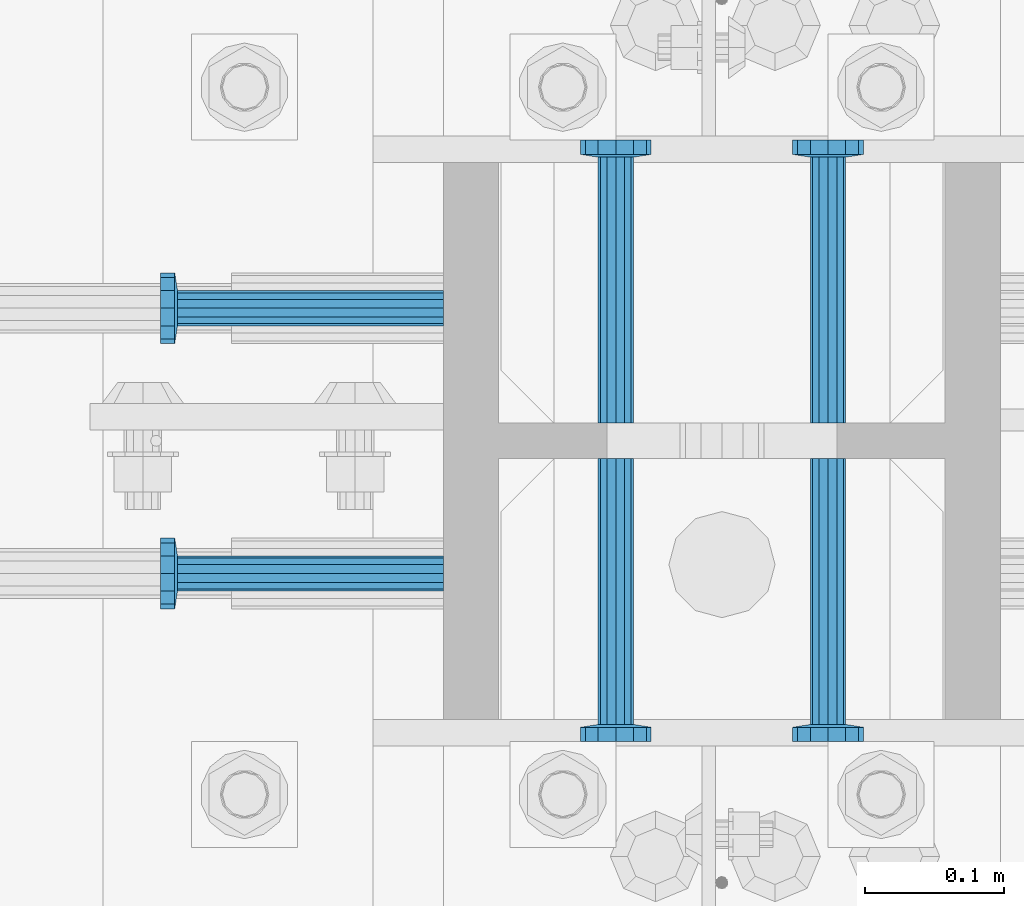
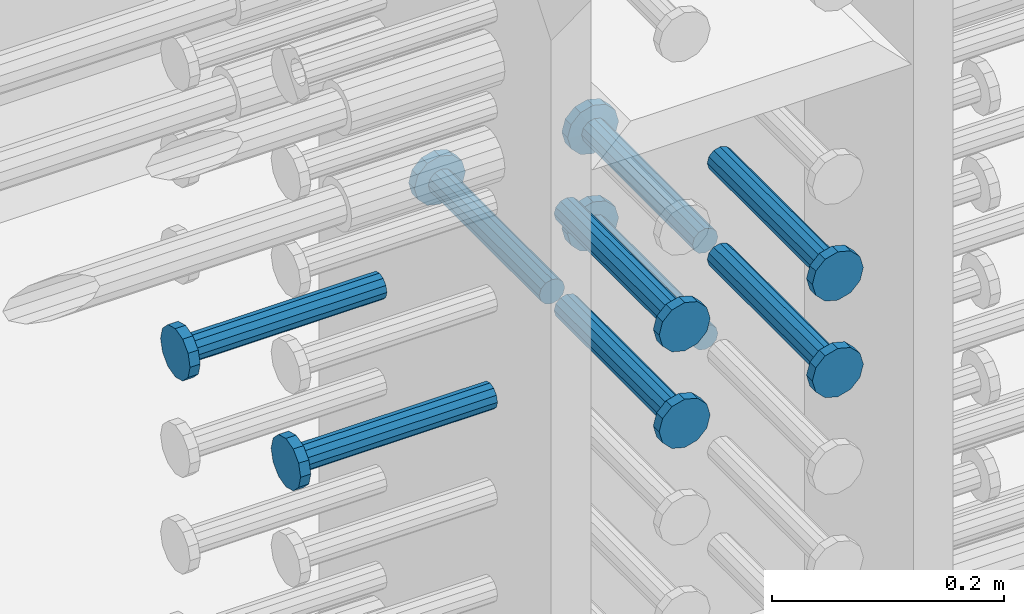
# One storey, part 1191 of 1763: 9 beams, 1 element without a shape of its own.
"""IFC2X3 building model written with IfcOpenShell, lengths in millimetres."""

import ifcopenshell
import ifcopenshell.guid

model = None  # the IFC model being written
_history = None  # IfcOwnerHistory: only IFC2X3 demands one
_inside = {}  # id of a spatial element -> (the spatial element, [elements in it])
_under = {}  # id of a project, library or spatial element -> (it, [spatial elements below it])
_declared = {}  # id of a project -> (the project, [libraries it declares])
_typed = {}  # id of a type object -> (the type object, [elements of that type])
_made_of = {}  # id of a material, layer set ... -> (it, [elements and type objects made of it])


def new_model(schema):
    """Start an empty IFC model of exactly this schema.

    Asked for "IFC4X3", IfcOpenShell would pick the latest addendum, in which some entities
    have other attributes; the version numbers below select the first issue.
    IFC2X3 requires an IfcOwnerHistory on every rooted entity: one is made here for all.
    """
    global model, _history
    if schema == "IFC4X3":
        model = ifcopenshell.file(schema_version=(4, 3, 0, 0))
    else:
        model = ifcopenshell.file(schema=schema)
    _inside.clear()
    _under.clear()
    _declared.clear()
    _typed.clear()
    _made_of.clear()
    _history = None
    if model.schema == "IFC2X3":
        org = make("IfcOrganization", Name="unknown")
        user = make(
            "IfcPersonAndOrganization",
            ThePerson=make("IfcPerson", FamilyName="unknown"),
            TheOrganization=org,
        )
        app = make(
            "IfcApplication",
            ApplicationDeveloper=org,
            Version="unknown",
            ApplicationFullName="unknown",
            ApplicationIdentifier="unknown",
        )
        _history = make(
            "IfcOwnerHistory",
            OwningUser=user,
            OwningApplication=app,
            ChangeAction="ADDED",
            CreationDate=0,
        )
    return model


def make(cls, **values):
    """One entity of the class cls with the attributes given. An attribute that is None is left unset."""
    return model.create_entity(
        cls, **{name: value for name, value in values.items() if value is not None}
    )


def rooted(cls, **values):
    """An entity with a GlobalId (a new one), such as an element, a storey or a relation."""
    return make(cls, GlobalId=ifcopenshell.guid.new(), OwnerHistory=_history, **values)


def si_unit(unit_type, name, prefix=None):
    """IfcSIUnit, for example si_unit("LENGTHUNIT", "METRE", prefix="MILLI")."""
    return make("IfcSIUnit", UnitType=unit_type, Prefix=prefix, Name=name)


def assignment(units):
    """IfcUnitAssignment: the units of a project."""
    return None if units is None else make("IfcUnitAssignment", Units=units)


def point(xyz):
    """IfcCartesianPoint."""
    return None if xyz is None else make("IfcCartesianPoint", Coordinates=xyz)


def direction(xyz):
    """IfcDirection."""
    return None if xyz is None else make("IfcDirection", DirectionRatios=xyz)


def frame(location, z_axis=None, x_axis=None):
    """IfcAxis2Placement3D, a coordinate frame: its origin and axes. An axis left out is left unset."""
    return make(
        "IfcAxis2Placement3D",
        Location=point(location),
        Axis=direction(z_axis),
        RefDirection=direction(x_axis),
    )


def origin_with_axes():
    """The frame at (0, 0, 0) with the z axis (0, 0, 1) and the x axis (1, 0, 0) written out."""
    return frame((0.0, 0.0, 0.0), z_axis=(0.0, 0.0, 1.0), x_axis=(1.0, 0.0, 0.0))


def place(relative_to, where):
    """IfcLocalPlacement: puts the frame where relative to a parent placement (None: the world)."""
    return make(
        "IfcLocalPlacement", PlacementRelTo=relative_to, RelativePlacement=where
    )


def context(
    kind, dimensions, precision=None, world=None, true_north=None, identifier=None
):
    """IfcGeometricRepresentationContext, for example the 3D "Model" context."""
    return make(
        "IfcGeometricRepresentationContext",
        ContextIdentifier=identifier,
        ContextType=kind,
        CoordinateSpaceDimension=dimensions,
        Precision=precision,
        WorldCoordinateSystem=world,
        TrueNorth=true_north,
    )


def subcontext(parent, identifier, kind, view, scale=None):
    """IfcGeometricRepresentationSubContext, for example "Body" below "Model"."""
    return make(
        "IfcGeometricRepresentationSubContext",
        ContextIdentifier=identifier,
        ContextType=kind,
        ParentContext=parent,
        TargetScale=scale,
        TargetView=view,
    )


def project(units=None, contexts=None):
    """IfcProject with its units and contexts."""
    return rooted(
        "IfcProject",
        Name="project",
        RepresentationContexts=contexts,
        UnitsInContext=assignment(units),
    )


def spatial(cls, under=None, at=None, **own):
    """A site, building, storey or space (cls), placed at a placement, below another one or the project."""
    s = rooted(cls, ObjectPlacement=at, **own)
    if under is not None:
        _under.setdefault(under.id(), (under, []))[1].append(s)
    return s


def faces_of(points, faces, orient=None, outer=None):
    """IfcFace entities. A face is a list of loops; a loop is a list of indices into points, from 0.

    orient and outer hold one flag for each loop. By default every Orientation is true, the
    first loop of a face is its IfcFaceOuterBound and the others are IfcFaceBound.
    """
    made = []
    for i, loops in enumerate(faces):
        bounds = []
        for j, loop in enumerate(loops):
            is_outer = j == 0 if outer is None else outer[i][j]
            bounds.append(
                make(
                    "IfcFaceOuterBound" if is_outer else "IfcFaceBound",
                    Bound=make("IfcPolyLoop", Polygon=[points[k] for k in loop]),
                    Orientation=True if orient is None else orient[i][j],
                )
            )
        made.append(make("IfcFace", Bounds=bounds))
    return made


def faceted_brep(points, faces, orient=None, outer=None, voids=None):
    """IfcFacetedBrep: a solid bounded by flat faces; with voids (closed shells), ...WithVoids."""
    shared = [point(p) for p in points]
    hull = make("IfcClosedShell", CfsFaces=faces_of(shared, faces, orient, outer))
    if voids is None:
        return make("IfcFacetedBrep", Outer=hull)
    return make(
        "IfcFacetedBrepWithVoids",
        Outer=hull,
        Voids=[
            make(cls, CfsFaces=faces_of(shared, fs, o, b)) for cls, fs, o, b in voids
        ],
    )


def shape(context_of_items, identifier, shape_type, items):
    """IfcShapeRepresentation: the items that make up one representation, for example the "Body"."""
    return make(
        "IfcShapeRepresentation",
        ContextOfItems=context_of_items,
        RepresentationIdentifier=identifier,
        RepresentationType=shape_type,
        Items=items,
    )


def material(Name=None, Category=None):
    """IfcMaterial."""
    return make("IfcMaterial", Name=Name, Category=Category)


def made_of(thing, what):
    """Note that an element or type object is made of a material, layer set ...; save() writes the relation."""
    if what is not None:
        _made_of.setdefault(what.id(), (what, []))[1].append(thing)
    return thing


def type_object(cls, material=None, **own):
    """A type object (cls), such as IfcWallType, which elements share."""
    return made_of(rooted(cls, **own), material)


def element(
    cls,
    number,
    at=None,
    inside=None,
    cuts=None,
    type_object=None,
    material=None,
    context=None,
    identifier="Body",
    shape_type=None,
    held_by="IfcProductDefinitionShape",
    body=None,
    shapes=None,
    **own,
):
    """One element of the class cls, such as IfcWall. Its Tag is "e" and its number.

    at: its placement. inside: the storey or other place that contains it. cuts: it is an
    opening in that element (IfcRelVoidsElement). A single representation is given by context,
    identifier, shape_type and body (its items); several are given by shapes. held_by: the class
    of the entity that holds the representations. save() writes the other relations.
    """
    e = rooted(cls, Tag="e%d" % number, ObjectPlacement=at, **own)
    if body is not None:
        shapes = [shape(context, identifier, shape_type, body)]
    if shapes is not None:
        e.Representation = make(held_by, Representations=shapes)
    if inside is not None:
        _inside.setdefault(inside.id(), (inside, []))[1].append(e)
    if cuts is not None:
        rooted(
            "IfcRelVoidsElement", RelatingBuildingElement=cuts, RelatedOpeningElement=e
        )
    if type_object is not None:
        _typed.setdefault(type_object.id(), (type_object, []))[1].append(e)
    return made_of(e, material)


def aggregate(whole, parts):
    """IfcRelAggregates: a whole, such as a stair, and the parts it consists of."""
    return rooted("IfcRelAggregates", RelatingObject=whole, RelatedObjects=parts)


def save(model, path):
    """Write the relations noted so far, then the file.

    IfcRelAggregates (storeys below a building ...), IfcRelContainedInSpatialStructure (elements
    in a storey), IfcRelDefinesByType, IfcRelAssociatesMaterial and IfcRelDeclares: one each for
    every whole, place, type object, material and project.
    """
    for whole, parts in _under.values():
        aggregate(whole, parts)
    for where, things in _inside.values():
        rooted(
            "IfcRelContainedInSpatialStructure",
            RelatedElements=things,
            RelatingStructure=where,
        )
    for kind, things in _typed.values():
        rooted("IfcRelDefinesByType", RelatedObjects=things, RelatingType=kind)
    for what, things in _made_of.values():
        rooted("IfcRelAssociatesMaterial", RelatedObjects=things, RelatingMaterial=what)
    for by, libraries in _declared.values():
        rooted("IfcRelDeclares", RelatingContext=by, RelatedDefinitions=libraries)
    model.write(path)


model = new_model("IFC2X3")

# Units and contexts
model_context = context("Model", 3, precision=1e-05, world=origin_with_axes())
body_context = subcontext(model_context, "Body", "Model", "MODEL_VIEW")
ifc_project = project(units=[si_unit("LENGTHUNIT", "METRE", prefix="MILLI"), si_unit("AREAUNIT", "SQUARE_METRE"), si_unit("VOLUMEUNIT", "CUBIC_METRE"), si_unit("MASSUNIT", "GRAM", prefix="KILO"), si_unit("TIMEUNIT", "SECOND"), si_unit("PLANEANGLEUNIT", "RADIAN"), si_unit("SOLIDANGLEUNIT", "STERADIAN"), si_unit("THERMODYNAMICTEMPERATUREUNIT", "DEGREE_CELSIUS"), si_unit("LUMINOUSINTENSITYUNIT", "LUMEN")], contexts=[model_context])

# Site, building, storey
site_placement = place(None, origin_with_axes())
site = spatial("IfcSite", under=ifc_project, at=site_placement, CompositionType="ELEMENT")
building_placement = place(site_placement, origin_with_axes())
building = spatial("IfcBuilding", under=site, at=building_placement, Name="Undefined", CompositionType="ELEMENT")
storey_placement = place(building_placement, origin_with_axes())
storey = spatial("IfcBuildingStorey", under=building, at=storey_placement, Name="Undefined", CompositionType="ELEMENT", Elevation=0.0)

# Assembly, beams
assembly_placement = place(storey_placement, origin_with_axes())
assembly = element("IfcElementAssembly", 1, at=assembly_placement, inside=storey, Name="COLUMN", AssemblyPlace="NOTDEFINED", PredefinedType="RIGID_FRAME")
ifc_material = material(Name="STEEL/A108")
beam_type = type_object("IfcBeamType", PredefinedType="NOTDEFINED")
beam_1_placement = place(assembly_placement, frame((-72567.2373420903, 444.499999886566, 4622.80000000005), z_axis=(1.0, 0.0, 0.0), x_axis=(0.0, -1.0, 0.0)))
beam_1 = element("IfcBeam", 2, at=beam_1_placement, type_object=beam_type, material=ifc_material, Name="HEADED STUD ANCHOR", context=body_context, shape_type="Brep", body=[
    faceted_brep([(0.0, -12.6999999999971, -1.81898940354586e-12), (3.63797880709171e-12, -11.0, -6.34999990463257), (191.00799999576, -11.0, -6.34999990454889), (191.007999995752, -12.6999998092651, 8.36735125631094e-11), (7.27595761418343e-12, -6.34999990463257, -11.0), (191.00799999576, -6.34999990463257, -10.9999999999163), (3.63797880709171e-12, 0.0, -12.6999998092651), (191.00799999576, 0.0, -12.6999998091815), (7.27595761418343e-12, 6.34999990463257, -11.0), (191.00799999576, 6.34999990463257, -10.9999999999163), (3.63797880709171e-12, 11.0, -6.34999990463257), (191.00799999576, 11.0, -6.34999990454889), (0.0, 12.6999999999971, -1.81898940354586e-12), (191.007999995752, 12.6999998092651, 8.36735125631094e-11), (0.0, 11.0, 6.34999990463257), (191.007999995752, 11.0, 6.34999990471624), (-3.63797880709171e-12, 6.34999990463257, 11.0), (191.007999995749, 6.34999990463257, 11.0000000000837), (-3.63797880709171e-12, 0.0, 12.6999998092651), (191.007999995749, 0.0, 12.6999998093488), (-3.63797880709171e-12, -6.34999990463257, 11.0), (191.007999995749, -6.34999990463257, 11.0000000000837), (0.0, -11.0, 6.34999990463257), (191.007999995752, -11.0, 6.34999990471624), (193.039999995715, -22.0, -12.6999998091796), (193.039999995708, -25.3999996185303, 8.54925019666553e-11), (193.039999995719, -12.6999998092651, -21.9999999999145), (193.039999995719, 0.0, -25.3999996184448), (193.039999995719, 12.6999998092651, -21.9999999999145), (193.039999995715, 22.0, -12.6999998091796), (193.039999995708, 25.3999996185303, 8.54925019666553e-11), (193.039999995704, 22.0, 12.6999998093506), (193.039999995701, 12.6999998092651, 22.0000000000855), (193.039999995697, 0.0, 25.3999996186158), (193.039999995701, -12.6999998092651, 22.0000000000855), (193.039999995704, -22.0, 12.6999998093506), (203.199999995486, -22.0, -12.6999998091742), (203.199999995482, -25.3999996185303, 9.09494701772928e-11), (203.199999995493, -12.6999998092651, -21.9999999999091), (203.199999995493, 0.0, -25.3999996184393), (203.199999995493, 12.6999998092651, -21.9999999999091), (203.199999995486, 22.0, -12.6999998091742), (203.199999995482, 25.3999996185303, 9.09494701772928e-11), (203.199999995479, 22.0, 12.6999998093561), (203.199999995475, 12.6999998092651, 22.0000000000909), (203.199999995471, 0.0, 25.3999996186212), (203.199999995475, -12.6999998092651, 22.0000000000909), (203.199999995479, -22.0, 12.6999998093561)], [[[0, 1, 2, 3]], [[1, 4, 5, 2]], [[4, 6, 7, 5]], [[6, 8, 9, 7]], [[8, 10, 11, 9]], [[10, 12, 13, 11]], [[12, 14, 15, 13]], [[14, 16, 17, 15]], [[16, 18, 19, 17]], [[18, 20, 21, 19]], [[20, 22, 23, 21]], [[22, 0, 3, 23]], [[22, 20, 18, 16, 14, 12, 10, 8, 6, 4, 1, 0]], [[3, 2, 24, 25]], [[2, 5, 26, 24]], [[5, 7, 27, 26]], [[7, 9, 28, 27]], [[9, 11, 29, 28]], [[11, 13, 30, 29]], [[13, 15, 31, 30]], [[15, 17, 32, 31]], [[17, 19, 33, 32]], [[19, 21, 34, 33]], [[21, 23, 35, 34]], [[23, 3, 25, 35]], [[25, 24, 36, 37]], [[24, 26, 38, 36]], [[26, 27, 39, 38]], [[27, 28, 40, 39]], [[28, 29, 41, 40]], [[29, 30, 42, 41]], [[30, 31, 43, 42]], [[31, 32, 44, 43]], [[32, 33, 45, 44]], [[33, 34, 46, 45]], [[34, 35, 47, 46]], [[35, 25, 37, 47]], [[38, 39, 40, 41, 42, 43, 44, 45, 46, 47, 37, 36]]]),
])
beam_2_placement = place(assembly_placement, frame((-72414.8373420912, 444.500000000843, 4622.80000000005), z_axis=(1.0, 0.0, 0.0), x_axis=(0.0, -1.0, 0.0)))
beam_2 = element("IfcBeam", 3, at=beam_2_placement, type_object=beam_type, material=ifc_material, Name="HEADED STUD ANCHOR", context=body_context, shape_type="Brep", body=[
    faceted_brep([(0.0, -12.6999999999971, -1.81898940354586e-12), (3.63797880709171e-12, -11.0, -6.34999990463257), (191.00799999576, -11.0, -6.34999990454889), (191.007999995752, -12.6999998092651, 8.36735125631094e-11), (7.27595761418343e-12, -6.34999990463257, -11.0), (191.00799999576, -6.34999990463257, -10.9999999999163), (3.63797880709171e-12, 0.0, -12.6999998092651), (191.00799999576, 0.0, -12.6999998091815), (7.27595761418343e-12, 6.34999990463257, -11.0), (191.00799999576, 6.34999990463257, -10.9999999999163), (3.63797880709171e-12, 11.0, -6.34999990463257), (191.00799999576, 11.0, -6.34999990454889), (0.0, 12.6999999999971, -1.81898940354586e-12), (191.007999995752, 12.6999998092651, 8.36735125631094e-11), (0.0, 11.0, 6.34999990463257), (191.007999995752, 11.0, 6.34999990471624), (-3.63797880709171e-12, 6.34999990463257, 11.0), (191.007999995749, 6.34999990463257, 11.0000000000837), (-3.63797880709171e-12, 0.0, 12.6999998092651), (191.007999995749, 0.0, 12.6999998093488), (-3.63797880709171e-12, -6.34999990463257, 11.0), (191.007999995749, -6.34999990463257, 11.0000000000837), (0.0, -11.0, 6.34999990463257), (191.007999995752, -11.0, 6.34999990471624), (193.039999995715, -22.0, -12.6999998091796), (193.039999995708, -25.3999996185303, 8.54925019666553e-11), (193.039999995719, -12.6999998092651, -21.9999999999145), (193.039999995719, 0.0, -25.3999996184448), (193.039999995719, 12.6999998092651, -21.9999999999145), (193.039999995715, 22.0, -12.6999998091796), (193.039999995708, 25.3999996185303, 8.54925019666553e-11), (193.039999995704, 22.0, 12.6999998093506), (193.039999995701, 12.6999998092651, 22.0000000000855), (193.039999995697, 0.0, 25.3999996186158), (193.039999995701, -12.6999998092651, 22.0000000000855), (193.039999995704, -22.0, 12.6999998093506), (203.199999995486, -22.0, -12.6999998091742), (203.199999995482, -25.3999996185303, 9.09494701772928e-11), (203.199999995493, -12.6999998092651, -21.9999999999091), (203.199999995493, 0.0, -25.3999996184393), (203.199999995493, 12.6999998092651, -21.9999999999091), (203.199999995486, 22.0, -12.6999998091742), (203.199999995482, 25.3999996185303, 9.09494701772928e-11), (203.199999995479, 22.0, 12.6999998093561), (203.199999995475, 12.6999998092651, 22.0000000000909), (203.199999995471, 0.0, 25.3999996186212), (203.199999995475, -12.6999998092651, 22.0000000000909), (203.199999995479, -22.0, 12.6999998093561)], [[[0, 1, 2, 3]], [[1, 4, 5, 2]], [[4, 6, 7, 5]], [[6, 8, 9, 7]], [[8, 10, 11, 9]], [[10, 12, 13, 11]], [[12, 14, 15, 13]], [[14, 16, 17, 15]], [[16, 18, 19, 17]], [[18, 20, 21, 19]], [[20, 22, 23, 21]], [[22, 0, 3, 23]], [[22, 20, 18, 16, 14, 12, 10, 8, 6, 4, 1, 0]], [[3, 2, 24, 25]], [[2, 5, 26, 24]], [[5, 7, 27, 26]], [[7, 9, 28, 27]], [[9, 11, 29, 28]], [[11, 13, 30, 29]], [[13, 15, 31, 30]], [[15, 17, 32, 31]], [[17, 19, 33, 32]], [[19, 21, 34, 33]], [[21, 23, 35, 34]], [[23, 3, 25, 35]], [[25, 24, 36, 37]], [[24, 26, 38, 36]], [[26, 27, 39, 38]], [[27, 28, 40, 39]], [[28, 29, 41, 40]], [[29, 30, 42, 41]], [[30, 31, 43, 42]], [[31, 32, 44, 43]], [[32, 33, 45, 44]], [[33, 34, 46, 45]], [[34, 35, 47, 46]], [[35, 25, 37, 47]], [[38, 39, 40, 41, 42, 43, 44, 45, 46, 47, 37, 36]]]),
])
beam_3_placement = place(assembly_placement, frame((-72414.837343099, 469.900000000843, 4521.20000000005), z_axis=(1.0, 0.0, 0.0), x_axis=(0.0, 1.0, 0.0)))
beam_3 = element("IfcBeam", 4, at=beam_3_placement, type_object=beam_type, material=ifc_material, Name="HEADED STUD ANCHOR", context=body_context, shape_type="Brep", body=[
    faceted_brep([(0.0, -12.6999999999971, -1.81898940354586e-12), (3.63797880709171e-12, -11.0, -6.34999990463257), (191.00799999576, -11.0, -6.34999990454889), (191.007999995752, -12.6999998092651, 8.36735125631094e-11), (7.27595761418343e-12, -6.34999990463257, -11.0), (191.00799999576, -6.34999990463257, -10.9999999999163), (3.63797880709171e-12, 0.0, -12.6999998092651), (191.00799999576, 0.0, -12.6999998091815), (7.27595761418343e-12, 6.34999990463257, -11.0), (191.00799999576, 6.34999990463257, -10.9999999999163), (3.63797880709171e-12, 11.0, -6.34999990463257), (191.00799999576, 11.0, -6.34999990454889), (0.0, 12.6999999999971, -1.81898940354586e-12), (191.007999995752, 12.6999998092651, 8.36735125631094e-11), (0.0, 11.0, 6.34999990463257), (191.007999995752, 11.0, 6.34999990471624), (-3.63797880709171e-12, 6.34999990463257, 11.0), (191.007999995749, 6.34999990463257, 11.0000000000837), (-3.63797880709171e-12, 0.0, 12.6999998092651), (191.007999995749, 0.0, 12.6999998093488), (-3.63797880709171e-12, -6.34999990463257, 11.0), (191.007999995749, -6.34999990463257, 11.0000000000837), (0.0, -11.0, 6.34999990463257), (191.007999995752, -11.0, 6.34999990471624), (193.039999995715, -22.0, -12.6999998091796), (193.039999995708, -25.3999996185303, 8.54925019666553e-11), (193.039999995719, -12.6999998092651, -21.9999999999145), (193.039999995719, 0.0, -25.3999996184448), (193.039999995719, 12.6999998092651, -21.9999999999145), (193.039999995715, 22.0, -12.6999998091796), (193.039999995708, 25.3999996185303, 8.54925019666553e-11), (193.039999995704, 22.0, 12.6999998093506), (193.039999995701, 12.6999998092651, 22.0000000000855), (193.039999995697, 0.0, 25.3999996186158), (193.039999995701, -12.6999998092651, 22.0000000000855), (193.039999995704, -22.0, 12.6999998093506), (203.199999995486, -22.0, -12.6999998091742), (203.199999995482, -25.3999996185303, 9.09494701772928e-11), (203.199999995493, -12.6999998092651, -21.9999999999091), (203.199999995493, 0.0, -25.3999996184393), (203.199999995493, 12.6999998092651, -21.9999999999091), (203.199999995486, 22.0, -12.6999998091742), (203.199999995482, 25.3999996185303, 9.09494701772928e-11), (203.199999995479, 22.0, 12.6999998093561), (203.199999995475, 12.6999998092651, 22.0000000000909), (203.199999995471, 0.0, 25.3999996186212), (203.199999995475, -12.6999998092651, 22.0000000000909), (203.199999995479, -22.0, 12.6999998093561)], [[[0, 1, 2, 3]], [[1, 4, 5, 2]], [[4, 6, 7, 5]], [[6, 8, 9, 7]], [[8, 10, 11, 9]], [[10, 12, 13, 11]], [[12, 14, 15, 13]], [[14, 16, 17, 15]], [[16, 18, 19, 17]], [[18, 20, 21, 19]], [[20, 22, 23, 21]], [[22, 0, 3, 23]], [[22, 20, 18, 16, 14, 12, 10, 8, 6, 4, 1, 0]], [[3, 2, 24, 25]], [[2, 5, 26, 24]], [[5, 7, 27, 26]], [[7, 9, 28, 27]], [[9, 11, 29, 28]], [[11, 13, 30, 29]], [[13, 15, 31, 30]], [[15, 17, 32, 31]], [[17, 19, 33, 32]], [[19, 21, 34, 33]], [[21, 23, 35, 34]], [[23, 3, 25, 35]], [[25, 24, 36, 37]], [[24, 26, 38, 36]], [[26, 27, 39, 38]], [[27, 28, 40, 39]], [[28, 29, 41, 40]], [[29, 30, 42, 41]], [[30, 31, 43, 42]], [[31, 32, 44, 43]], [[32, 33, 45, 44]], [[33, 34, 46, 45]], [[34, 35, 47, 46]], [[35, 25, 37, 47]], [[38, 39, 40, 41, 42, 43, 44, 45, 46, 47, 37, 36]]]),
])
beam_4_placement = place(assembly_placement, frame((-72567.2373430988, 469.899999003702, 4521.20000000005), z_axis=(1.0, 0.0, 0.0), x_axis=(0.0, 1.0, 0.0)))
beam_4 = element("IfcBeam", 5, at=beam_4_placement, type_object=beam_type, material=ifc_material, Name="HEADED STUD ANCHOR", context=body_context, shape_type="Brep", body=[
    faceted_brep([(0.0, -12.6999999999971, -1.81898940354586e-12), (3.63797880709171e-12, -11.0, -6.34999990463257), (191.00799999576, -11.0, -6.34999990454889), (191.007999995752, -12.6999998092651, 8.36735125631094e-11), (7.27595761418343e-12, -6.34999990463257, -11.0), (191.00799999576, -6.34999990463257, -10.9999999999163), (3.63797880709171e-12, 0.0, -12.6999998092651), (191.00799999576, 0.0, -12.6999998091815), (7.27595761418343e-12, 6.34999990463257, -11.0), (191.00799999576, 6.34999990463257, -10.9999999999163), (3.63797880709171e-12, 11.0, -6.34999990463257), (191.00799999576, 11.0, -6.34999990454889), (0.0, 12.6999999999971, -1.81898940354586e-12), (191.007999995752, 12.6999998092651, 8.36735125631094e-11), (0.0, 11.0, 6.34999990463257), (191.007999995752, 11.0, 6.34999990471624), (-3.63797880709171e-12, 6.34999990463257, 11.0), (191.007999995749, 6.34999990463257, 11.0000000000837), (-3.63797880709171e-12, 0.0, 12.6999998092651), (191.007999995749, 0.0, 12.6999998093488), (-3.63797880709171e-12, -6.34999990463257, 11.0), (191.007999995749, -6.34999990463257, 11.0000000000837), (0.0, -11.0, 6.34999990463257), (191.007999995752, -11.0, 6.34999990471624), (193.039999995715, -22.0, -12.6999998091796), (193.039999995708, -25.3999996185303, 8.54925019666553e-11), (193.039999995719, -12.6999998092651, -21.9999999999145), (193.039999995719, 0.0, -25.3999996184448), (193.039999995719, 12.6999998092651, -21.9999999999145), (193.039999995715, 22.0, -12.6999998091796), (193.039999995708, 25.3999996185303, 8.54925019666553e-11), (193.039999995704, 22.0, 12.6999998093506), (193.039999995701, 12.6999998092651, 22.0000000000855), (193.039999995697, 0.0, 25.3999996186158), (193.039999995701, -12.6999998092651, 22.0000000000855), (193.039999995704, -22.0, 12.6999998093506), (203.199999995486, -22.0, -12.6999998091742), (203.199999995482, -25.3999996185303, 9.09494701772928e-11), (203.199999995493, -12.6999998092651, -21.9999999999091), (203.199999995493, 0.0, -25.3999996184393), (203.199999995493, 12.6999998092651, -21.9999999999091), (203.199999995486, 22.0, -12.6999998091742), (203.199999995482, 25.3999996185303, 9.09494701772928e-11), (203.199999995479, 22.0, 12.6999998093561), (203.199999995475, 12.6999998092651, 22.0000000000909), (203.199999995471, 0.0, 25.3999996186212), (203.199999995475, -12.6999998092651, 22.0000000000909), (203.199999995479, -22.0, 12.6999998093561)], [[[0, 1, 2, 3]], [[1, 4, 5, 2]], [[4, 6, 7, 5]], [[6, 8, 9, 7]], [[8, 10, 11, 9]], [[10, 12, 13, 11]], [[12, 14, 15, 13]], [[14, 16, 17, 15]], [[16, 18, 19, 17]], [[18, 20, 21, 19]], [[20, 22, 23, 21]], [[22, 0, 3, 23]], [[22, 20, 18, 16, 14, 12, 10, 8, 6, 4, 1, 0]], [[3, 2, 24, 25]], [[2, 5, 26, 24]], [[5, 7, 27, 26]], [[7, 9, 28, 27]], [[9, 11, 29, 28]], [[11, 13, 30, 29]], [[13, 15, 31, 30]], [[15, 17, 32, 31]], [[17, 19, 33, 32]], [[19, 21, 34, 33]], [[21, 23, 35, 34]], [[23, 3, 25, 35]], [[25, 24, 36, 37]], [[24, 26, 38, 36]], [[26, 27, 39, 38]], [[27, 28, 40, 39]], [[28, 29, 41, 40]], [[29, 30, 42, 41]], [[30, 31, 43, 42]], [[31, 32, 44, 43]], [[32, 33, 45, 44]], [[33, 34, 46, 45]], [[34, 35, 47, 46]], [[35, 25, 37, 47]], [[38, 39, 40, 41, 42, 43, 44, 45, 46, 47, 37, 36]]]),
])
beam_5_placement = place(assembly_placement, frame((-72691.0622049617, 552.45000000066, 4521.20000000005), z_axis=(0.0, 1.0, 0.0), x_axis=(-1.0, 0.0, 0.0)))
beam_5 = element("IfcBeam", 6, at=beam_5_placement, type_object=beam_type, material=ifc_material, Name="HEADED STUD ANCHOR", context=body_context, shape_type="Brep", body=[
    faceted_brep([(0.0, -12.6999999999971, -1.81898940354586e-12), (3.63797880709171e-12, -11.0, -6.34999990463257), (191.00799999576, -11.0, -6.34999990454889), (191.007999995752, -12.6999998092651, 8.36735125631094e-11), (7.27595761418343e-12, -6.34999990463257, -11.0), (191.00799999576, -6.34999990463257, -10.9999999999163), (3.63797880709171e-12, 0.0, -12.6999998092651), (191.00799999576, 0.0, -12.6999998091815), (7.27595761418343e-12, 6.34999990463257, -11.0), (191.00799999576, 6.34999990463257, -10.9999999999163), (3.63797880709171e-12, 11.0, -6.34999990463257), (191.00799999576, 11.0, -6.34999990454889), (0.0, 12.6999999999971, -1.81898940354586e-12), (191.007999995752, 12.6999998092651, 8.36735125631094e-11), (0.0, 11.0, 6.34999990463257), (191.007999995752, 11.0, 6.34999990471624), (-3.63797880709171e-12, 6.34999990463257, 11.0), (191.007999995749, 6.34999990463257, 11.0000000000837), (-3.63797880709171e-12, 0.0, 12.6999998092651), (191.007999995749, 0.0, 12.6999998093488), (-3.63797880709171e-12, -6.34999990463257, 11.0), (191.007999995749, -6.34999990463257, 11.0000000000837), (0.0, -11.0, 6.34999990463257), (191.007999995752, -11.0, 6.34999990471624), (193.039999995715, -22.0, -12.6999998091796), (193.039999995708, -25.3999996185303, 8.54925019666553e-11), (193.039999995719, -12.6999998092651, -21.9999999999145), (193.039999995719, 0.0, -25.3999996184448), (193.039999995719, 12.6999998092651, -21.9999999999145), (193.039999995715, 22.0, -12.6999998091796), (193.039999995708, 25.3999996185303, 8.54925019666553e-11), (193.039999995704, 22.0, 12.6999998093506), (193.039999995701, 12.6999998092651, 22.0000000000855), (193.039999995697, 0.0, 25.3999996186158), (193.039999995701, -12.6999998092651, 22.0000000000855), (193.039999995704, -22.0, 12.6999998093506), (203.199999995486, -22.0, -12.6999998091742), (203.199999995482, -25.3999996185303, 9.09494701772928e-11), (203.199999995493, -12.6999998092651, -21.9999999999091), (203.199999995493, 0.0, -25.3999996184393), (203.199999995493, 12.6999998092651, -21.9999999999091), (203.199999995486, 22.0, -12.6999998091742), (203.199999995482, 25.3999996185303, 9.09494701772928e-11), (203.199999995479, 22.0, 12.6999998093561), (203.199999995475, 12.6999998092651, 22.0000000000909), (203.199999995471, 0.0, 25.3999996186212), (203.199999995475, -12.6999998092651, 22.0000000000909), (203.199999995479, -22.0, 12.6999998093561)], [[[0, 1, 2, 3]], [[1, 4, 5, 2]], [[4, 6, 7, 5]], [[6, 8, 9, 7]], [[8, 10, 11, 9]], [[10, 12, 13, 11]], [[12, 14, 15, 13]], [[14, 16, 17, 15]], [[16, 18, 19, 17]], [[18, 20, 21, 19]], [[20, 22, 23, 21]], [[22, 0, 3, 23]], [[22, 20, 18, 16, 14, 12, 10, 8, 6, 4, 1, 0]], [[3, 2, 24, 25]], [[2, 5, 26, 24]], [[5, 7, 27, 26]], [[7, 9, 28, 27]], [[9, 11, 29, 28]], [[11, 13, 30, 29]], [[13, 15, 31, 30]], [[15, 17, 32, 31]], [[17, 19, 33, 32]], [[19, 21, 34, 33]], [[21, 23, 35, 34]], [[23, 3, 25, 35]], [[25, 24, 36, 37]], [[24, 26, 38, 36]], [[26, 27, 39, 38]], [[27, 28, 40, 39]], [[28, 29, 41, 40]], [[29, 30, 42, 41]], [[30, 31, 43, 42]], [[31, 32, 44, 43]], [[32, 33, 45, 44]], [[33, 34, 46, 45]], [[34, 35, 47, 46]], [[35, 25, 37, 47]], [[38, 39, 40, 41, 42, 43, 44, 45, 46, 47, 37, 36]]]),
])
beam_6_placement = place(assembly_placement, frame((-72691.0622736973, 361.950000000834, 4521.20000000005), z_axis=(0.0, 1.0, 0.0), x_axis=(-1.0, 0.0, 0.0)))
beam_6 = element("IfcBeam", 7, at=beam_6_placement, type_object=beam_type, material=ifc_material, Name="HEADED STUD ANCHOR", context=body_context, shape_type="Brep", body=[
    faceted_brep([(0.0, -12.6999999999971, -1.81898940354586e-12), (3.63797880709171e-12, -11.0, -6.34999990463257), (191.00799999576, -11.0, -6.34999990454889), (191.007999995752, -12.6999998092651, 8.36735125631094e-11), (7.27595761418343e-12, -6.34999990463257, -11.0), (191.00799999576, -6.34999990463257, -10.9999999999163), (3.63797880709171e-12, 0.0, -12.6999998092651), (191.00799999576, 0.0, -12.6999998091815), (7.27595761418343e-12, 6.34999990463257, -11.0), (191.00799999576, 6.34999990463257, -10.9999999999163), (3.63797880709171e-12, 11.0, -6.34999990463257), (191.00799999576, 11.0, -6.34999990454889), (0.0, 12.6999999999971, -1.81898940354586e-12), (191.007999995752, 12.6999998092651, 8.36735125631094e-11), (0.0, 11.0, 6.34999990463257), (191.007999995752, 11.0, 6.34999990471624), (-3.63797880709171e-12, 6.34999990463257, 11.0), (191.007999995749, 6.34999990463257, 11.0000000000837), (-3.63797880709171e-12, 0.0, 12.6999998092651), (191.007999995749, 0.0, 12.6999998093488), (-3.63797880709171e-12, -6.34999990463257, 11.0), (191.007999995749, -6.34999990463257, 11.0000000000837), (0.0, -11.0, 6.34999990463257), (191.007999995752, -11.0, 6.34999990471624), (193.039999995715, -22.0, -12.6999998091796), (193.039999995708, -25.3999996185303, 8.54925019666553e-11), (193.039999995719, -12.6999998092651, -21.9999999999145), (193.039999995719, 0.0, -25.3999996184448), (193.039999995719, 12.6999998092651, -21.9999999999145), (193.039999995715, 22.0, -12.6999998091796), (193.039999995708, 25.3999996185303, 8.54925019666553e-11), (193.039999995704, 22.0, 12.6999998093506), (193.039999995701, 12.6999998092651, 22.0000000000855), (193.039999995697, 0.0, 25.3999996186158), (193.039999995701, -12.6999998092651, 22.0000000000855), (193.039999995704, -22.0, 12.6999998093506), (203.199999995486, -22.0, -12.6999998091742), (203.199999995482, -25.3999996185303, 9.09494701772928e-11), (203.199999995493, -12.6999998092651, -21.9999999999091), (203.199999995493, 0.0, -25.3999996184393), (203.199999995493, 12.6999998092651, -21.9999999999091), (203.199999995486, 22.0, -12.6999998091742), (203.199999995482, 25.3999996185303, 9.09494701772928e-11), (203.199999995479, 22.0, 12.6999998093561), (203.199999995475, 12.6999998092651, 22.0000000000909), (203.199999995471, 0.0, 25.3999996186212), (203.199999995475, -12.6999998092651, 22.0000000000909), (203.199999995479, -22.0, 12.6999998093561)], [[[0, 1, 2, 3]], [[1, 4, 5, 2]], [[4, 6, 7, 5]], [[6, 8, 9, 7]], [[8, 10, 11, 9]], [[10, 12, 13, 11]], [[12, 14, 15, 13]], [[14, 16, 17, 15]], [[16, 18, 19, 17]], [[18, 20, 21, 19]], [[20, 22, 23, 21]], [[22, 0, 3, 23]], [[22, 20, 18, 16, 14, 12, 10, 8, 6, 4, 1, 0]], [[3, 2, 24, 25]], [[2, 5, 26, 24]], [[5, 7, 27, 26]], [[7, 9, 28, 27]], [[9, 11, 29, 28]], [[11, 13, 30, 29]], [[13, 15, 31, 30]], [[15, 17, 32, 31]], [[17, 19, 33, 32]], [[19, 21, 34, 33]], [[21, 23, 35, 34]], [[23, 3, 25, 35]], [[25, 24, 36, 37]], [[24, 26, 38, 36]], [[26, 27, 39, 38]], [[27, 28, 40, 39]], [[28, 29, 41, 40]], [[29, 30, 42, 41]], [[30, 31, 43, 42]], [[31, 32, 44, 43]], [[32, 33, 45, 44]], [[33, 34, 46, 45]], [[34, 35, 47, 46]], [[35, 25, 37, 47]], [[38, 39, 40, 41, 42, 43, 44, 45, 46, 47, 37, 36]]]),
])
beam_7_placement = place(assembly_placement, frame((-72567.2373420903, 444.499999886566, 4521.20000000005), z_axis=(1.0, 0.0, 0.0), x_axis=(0.0, -1.0, 0.0)))
beam_7 = element("IfcBeam", 8, at=beam_7_placement, type_object=beam_type, material=ifc_material, Name="HEADED STUD ANCHOR", context=body_context, shape_type="Brep", body=[
    faceted_brep([(0.0, -12.6999999999971, -1.81898940354586e-12), (3.63797880709171e-12, -11.0, -6.34999990463257), (191.00799999576, -11.0, -6.34999990454889), (191.007999995752, -12.6999998092651, 8.36735125631094e-11), (7.27595761418343e-12, -6.34999990463257, -11.0), (191.00799999576, -6.34999990463257, -10.9999999999163), (3.63797880709171e-12, 0.0, -12.6999998092651), (191.00799999576, 0.0, -12.6999998091815), (7.27595761418343e-12, 6.34999990463257, -11.0), (191.00799999576, 6.34999990463257, -10.9999999999163), (3.63797880709171e-12, 11.0, -6.34999990463257), (191.00799999576, 11.0, -6.34999990454889), (0.0, 12.6999999999971, -1.81898940354586e-12), (191.007999995752, 12.6999998092651, 8.36735125631094e-11), (0.0, 11.0, 6.34999990463257), (191.007999995752, 11.0, 6.34999990471624), (-3.63797880709171e-12, 6.34999990463257, 11.0), (191.007999995749, 6.34999990463257, 11.0000000000837), (-3.63797880709171e-12, 0.0, 12.6999998092651), (191.007999995749, 0.0, 12.6999998093488), (-3.63797880709171e-12, -6.34999990463257, 11.0), (191.007999995749, -6.34999990463257, 11.0000000000837), (0.0, -11.0, 6.34999990463257), (191.007999995752, -11.0, 6.34999990471624), (193.039999995715, -22.0, -12.6999998091796), (193.039999995708, -25.3999996185303, 8.54925019666553e-11), (193.039999995719, -12.6999998092651, -21.9999999999145), (193.039999995719, 0.0, -25.3999996184448), (193.039999995719, 12.6999998092651, -21.9999999999145), (193.039999995715, 22.0, -12.6999998091796), (193.039999995708, 25.3999996185303, 8.54925019666553e-11), (193.039999995704, 22.0, 12.6999998093506), (193.039999995701, 12.6999998092651, 22.0000000000855), (193.039999995697, 0.0, 25.3999996186158), (193.039999995701, -12.6999998092651, 22.0000000000855), (193.039999995704, -22.0, 12.6999998093506), (203.199999995486, -22.0, -12.6999998091742), (203.199999995482, -25.3999996185303, 9.09494701772928e-11), (203.199999995493, -12.6999998092651, -21.9999999999091), (203.199999995493, 0.0, -25.3999996184393), (203.199999995493, 12.6999998092651, -21.9999999999091), (203.199999995486, 22.0, -12.6999998091742), (203.199999995482, 25.3999996185303, 9.09494701772928e-11), (203.199999995479, 22.0, 12.6999998093561), (203.199999995475, 12.6999998092651, 22.0000000000909), (203.199999995471, 0.0, 25.3999996186212), (203.199999995475, -12.6999998092651, 22.0000000000909), (203.199999995479, -22.0, 12.6999998093561)], [[[0, 1, 2, 3]], [[1, 4, 5, 2]], [[4, 6, 7, 5]], [[6, 8, 9, 7]], [[8, 10, 11, 9]], [[10, 12, 13, 11]], [[12, 14, 15, 13]], [[14, 16, 17, 15]], [[16, 18, 19, 17]], [[18, 20, 21, 19]], [[20, 22, 23, 21]], [[22, 0, 3, 23]], [[22, 20, 18, 16, 14, 12, 10, 8, 6, 4, 1, 0]], [[3, 2, 24, 25]], [[2, 5, 26, 24]], [[5, 7, 27, 26]], [[7, 9, 28, 27]], [[9, 11, 29, 28]], [[11, 13, 30, 29]], [[13, 15, 31, 30]], [[15, 17, 32, 31]], [[17, 19, 33, 32]], [[19, 21, 34, 33]], [[21, 23, 35, 34]], [[23, 3, 25, 35]], [[25, 24, 36, 37]], [[24, 26, 38, 36]], [[26, 27, 39, 38]], [[27, 28, 40, 39]], [[28, 29, 41, 40]], [[29, 30, 42, 41]], [[30, 31, 43, 42]], [[31, 32, 44, 43]], [[32, 33, 45, 44]], [[33, 34, 46, 45]], [[34, 35, 47, 46]], [[35, 25, 37, 47]], [[38, 39, 40, 41, 42, 43, 44, 45, 46, 47, 37, 36]]]),
])
beam_8_placement = place(assembly_placement, frame((-72414.8373420912, 444.500000000843, 4521.20000000005), z_axis=(1.0, 0.0, 0.0), x_axis=(0.0, -1.0, 0.0)))
beam_8 = element("IfcBeam", 9, at=beam_8_placement, type_object=beam_type, material=ifc_material, Name="HEADED STUD ANCHOR", context=body_context, shape_type="Brep", body=[
    faceted_brep([(0.0, -12.6999999999971, -1.81898940354586e-12), (3.63797880709171e-12, -11.0, -6.34999990463257), (191.00799999576, -11.0, -6.34999990454889), (191.007999995752, -12.6999998092651, 8.36735125631094e-11), (7.27595761418343e-12, -6.34999990463257, -11.0), (191.00799999576, -6.34999990463257, -10.9999999999163), (3.63797880709171e-12, 0.0, -12.6999998092651), (191.00799999576, 0.0, -12.6999998091815), (7.27595761418343e-12, 6.34999990463257, -11.0), (191.00799999576, 6.34999990463257, -10.9999999999163), (3.63797880709171e-12, 11.0, -6.34999990463257), (191.00799999576, 11.0, -6.34999990454889), (0.0, 12.6999999999971, -1.81898940354586e-12), (191.007999995752, 12.6999998092651, 8.36735125631094e-11), (0.0, 11.0, 6.34999990463257), (191.007999995752, 11.0, 6.34999990471624), (-3.63797880709171e-12, 6.34999990463257, 11.0), (191.007999995749, 6.34999990463257, 11.0000000000837), (-3.63797880709171e-12, 0.0, 12.6999998092651), (191.007999995749, 0.0, 12.6999998093488), (-3.63797880709171e-12, -6.34999990463257, 11.0), (191.007999995749, -6.34999990463257, 11.0000000000837), (0.0, -11.0, 6.34999990463257), (191.007999995752, -11.0, 6.34999990471624), (193.039999995715, -22.0, -12.6999998091796), (193.039999995708, -25.3999996185303, 8.54925019666553e-11), (193.039999995719, -12.6999998092651, -21.9999999999145), (193.039999995719, 0.0, -25.3999996184448), (193.039999995719, 12.6999998092651, -21.9999999999145), (193.039999995715, 22.0, -12.6999998091796), (193.039999995708, 25.3999996185303, 8.54925019666553e-11), (193.039999995704, 22.0, 12.6999998093506), (193.039999995701, 12.6999998092651, 22.0000000000855), (193.039999995697, 0.0, 25.3999996186158), (193.039999995701, -12.6999998092651, 22.0000000000855), (193.039999995704, -22.0, 12.6999998093506), (203.199999995486, -22.0, -12.6999998091742), (203.199999995482, -25.3999996185303, 9.09494701772928e-11), (203.199999995493, -12.6999998092651, -21.9999999999091), (203.199999995493, 0.0, -25.3999996184393), (203.199999995493, 12.6999998092651, -21.9999999999091), (203.199999995486, 22.0, -12.6999998091742), (203.199999995482, 25.3999996185303, 9.09494701772928e-11), (203.199999995479, 22.0, 12.6999998093561), (203.199999995475, 12.6999998092651, 22.0000000000909), (203.199999995471, 0.0, 25.3999996186212), (203.199999995475, -12.6999998092651, 22.0000000000909), (203.199999995479, -22.0, 12.6999998093561)], [[[0, 1, 2, 3]], [[1, 4, 5, 2]], [[4, 6, 7, 5]], [[6, 8, 9, 7]], [[8, 10, 11, 9]], [[10, 12, 13, 11]], [[12, 14, 15, 13]], [[14, 16, 17, 15]], [[16, 18, 19, 17]], [[18, 20, 21, 19]], [[20, 22, 23, 21]], [[22, 0, 3, 23]], [[22, 20, 18, 16, 14, 12, 10, 8, 6, 4, 1, 0]], [[3, 2, 24, 25]], [[2, 5, 26, 24]], [[5, 7, 27, 26]], [[7, 9, 28, 27]], [[9, 11, 29, 28]], [[11, 13, 30, 29]], [[13, 15, 31, 30]], [[15, 17, 32, 31]], [[17, 19, 33, 32]], [[19, 21, 34, 33]], [[21, 23, 35, 34]], [[23, 3, 25, 35]], [[25, 24, 36, 37]], [[24, 26, 38, 36]], [[26, 27, 39, 38]], [[27, 28, 40, 39]], [[28, 29, 41, 40]], [[29, 30, 42, 41]], [[30, 31, 43, 42]], [[31, 32, 44, 43]], [[32, 33, 45, 44]], [[33, 34, 46, 45]], [[34, 35, 47, 46]], [[35, 25, 37, 47]], [[38, 39, 40, 41, 42, 43, 44, 45, 46, 47, 37, 36]]]),
])
beam_9_placement = place(assembly_placement, frame((-72414.837343099, 469.900000000843, 4419.60000000004), z_axis=(1.0, 0.0, 0.0), x_axis=(0.0, 1.0, 0.0)))
beam_9 = element("IfcBeam", 10, at=beam_9_placement, type_object=beam_type, material=ifc_material, Name="HEADED STUD ANCHOR", context=body_context, shape_type="Brep", body=[
    faceted_brep([(0.0, -12.6999999999971, -1.81898940354586e-12), (3.63797880709171e-12, -11.0, -6.34999990463257), (191.00799999576, -11.0, -6.34999990454889), (191.007999995752, -12.6999998092651, 8.36735125631094e-11), (7.27595761418343e-12, -6.34999990463257, -11.0), (191.00799999576, -6.34999990463257, -10.9999999999163), (3.63797880709171e-12, 0.0, -12.6999998092651), (191.00799999576, 0.0, -12.6999998091815), (7.27595761418343e-12, 6.34999990463257, -11.0), (191.00799999576, 6.34999990463257, -10.9999999999163), (3.63797880709171e-12, 11.0, -6.34999990463257), (191.00799999576, 11.0, -6.34999990454889), (0.0, 12.6999999999971, -1.81898940354586e-12), (191.007999995752, 12.6999998092651, 8.36735125631094e-11), (0.0, 11.0, 6.34999990463257), (191.007999995752, 11.0, 6.34999990471624), (-3.63797880709171e-12, 6.34999990463257, 11.0), (191.007999995749, 6.34999990463257, 11.0000000000837), (-3.63797880709171e-12, 0.0, 12.6999998092651), (191.007999995749, 0.0, 12.6999998093488), (-3.63797880709171e-12, -6.34999990463257, 11.0), (191.007999995749, -6.34999990463257, 11.0000000000837), (0.0, -11.0, 6.34999990463257), (191.007999995752, -11.0, 6.34999990471624), (193.039999995715, -22.0, -12.6999998091796), (193.039999995708, -25.3999996185303, 8.54925019666553e-11), (193.039999995719, -12.6999998092651, -21.9999999999145), (193.039999995719, 0.0, -25.3999996184448), (193.039999995719, 12.6999998092651, -21.9999999999145), (193.039999995715, 22.0, -12.6999998091796), (193.039999995708, 25.3999996185303, 8.54925019666553e-11), (193.039999995704, 22.0, 12.6999998093506), (193.039999995701, 12.6999998092651, 22.0000000000855), (193.039999995697, 0.0, 25.3999996186158), (193.039999995701, -12.6999998092651, 22.0000000000855), (193.039999995704, -22.0, 12.6999998093506), (203.199999995486, -22.0, -12.6999998091742), (203.199999995482, -25.3999996185303, 9.09494701772928e-11), (203.199999995493, -12.6999998092651, -21.9999999999091), (203.199999995493, 0.0, -25.3999996184393), (203.199999995493, 12.6999998092651, -21.9999999999091), (203.199999995486, 22.0, -12.6999998091742), (203.199999995482, 25.3999996185303, 9.09494701772928e-11), (203.199999995479, 22.0, 12.6999998093561), (203.199999995475, 12.6999998092651, 22.0000000000909), (203.199999995471, 0.0, 25.3999996186212), (203.199999995475, -12.6999998092651, 22.0000000000909), (203.199999995479, -22.0, 12.6999998093561)], [[[0, 1, 2, 3]], [[1, 4, 5, 2]], [[4, 6, 7, 5]], [[6, 8, 9, 7]], [[8, 10, 11, 9]], [[10, 12, 13, 11]], [[12, 14, 15, 13]], [[14, 16, 17, 15]], [[16, 18, 19, 17]], [[18, 20, 21, 19]], [[20, 22, 23, 21]], [[22, 0, 3, 23]], [[22, 20, 18, 16, 14, 12, 10, 8, 6, 4, 1, 0]], [[3, 2, 24, 25]], [[2, 5, 26, 24]], [[5, 7, 27, 26]], [[7, 9, 28, 27]], [[9, 11, 29, 28]], [[11, 13, 30, 29]], [[13, 15, 31, 30]], [[15, 17, 32, 31]], [[17, 19, 33, 32]], [[19, 21, 34, 33]], [[21, 23, 35, 34]], [[23, 3, 25, 35]], [[25, 24, 36, 37]], [[24, 26, 38, 36]], [[26, 27, 39, 38]], [[27, 28, 40, 39]], [[28, 29, 41, 40]], [[29, 30, 42, 41]], [[30, 31, 43, 42]], [[31, 32, 44, 43]], [[32, 33, 45, 44]], [[33, 34, 46, 45]], [[34, 35, 47, 46]], [[35, 25, 37, 47]], [[38, 39, 40, 41, 42, 43, 44, 45, 46, 47, 37, 36]]]),
])
aggregate(assembly, [beam_1, beam_2, beam_3, beam_4, beam_5, beam_6, beam_7, beam_8, beam_9])

save(model, "model.ifc")
